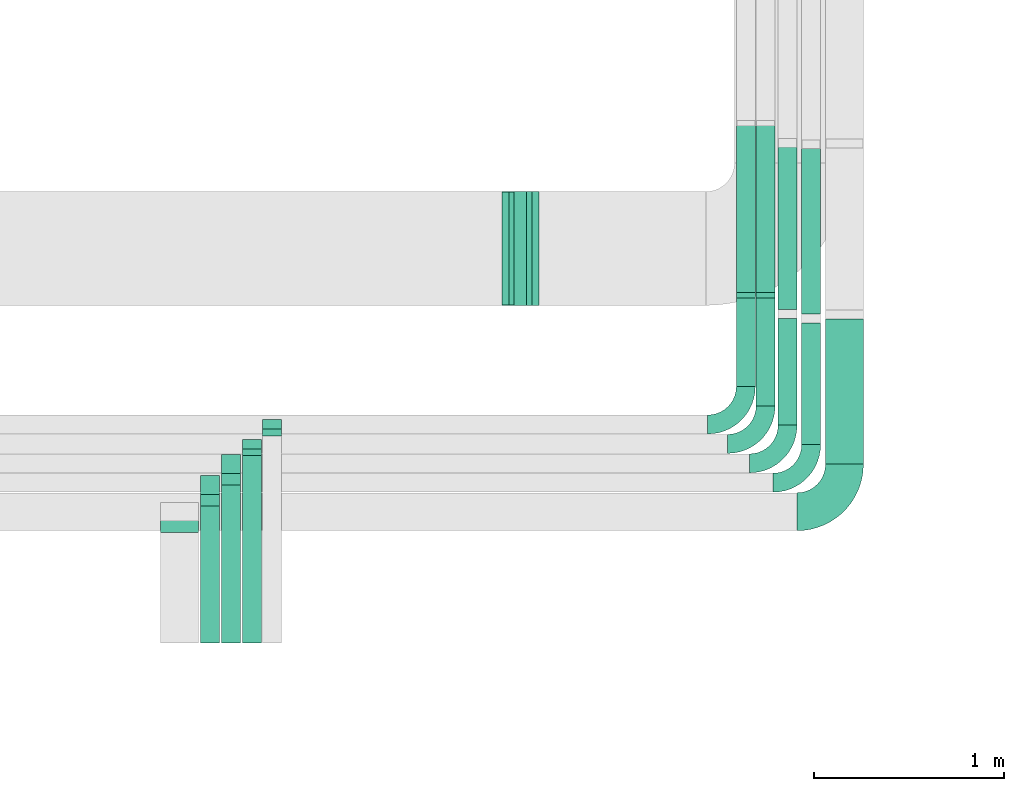
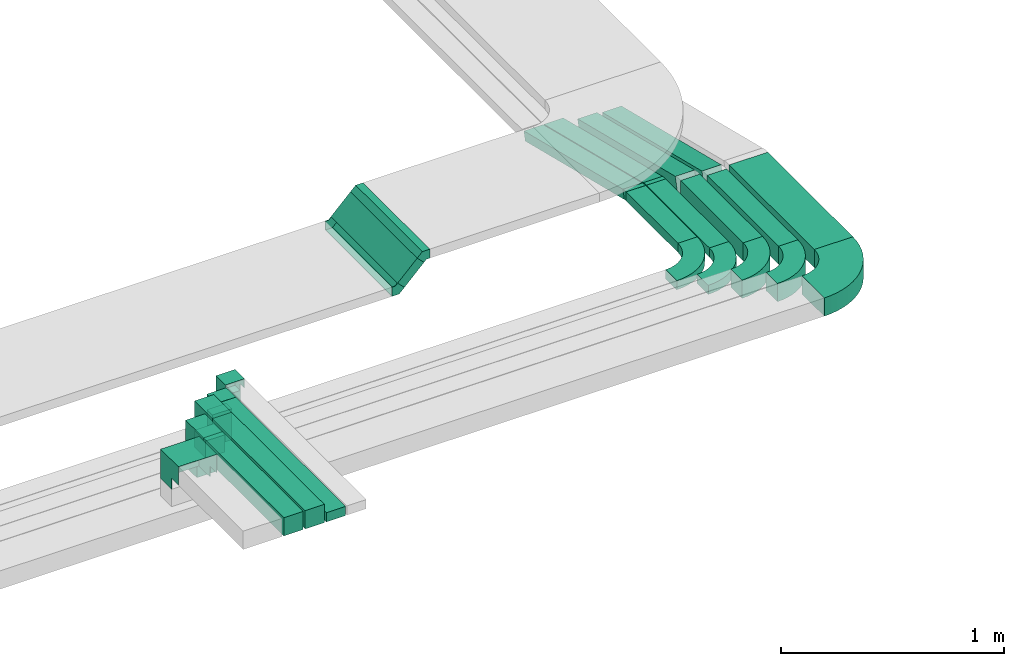
# One storey, part 17 of 38: 17 flow segments, 14 flow fittings.
"""IFC2X3 building model written with IfcOpenShell, lengths in millimetres."""

import ifcopenshell
import ifcopenshell.guid

model = None  # the IFC model being written
_history = None  # IfcOwnerHistory: only IFC2X3 demands one
_inside = {}  # id of a spatial element -> (the spatial element, [elements in it])
_under = {}  # id of a project, library or spatial element -> (it, [spatial elements below it])
_declared = {}  # id of a project -> (the project, [libraries it declares])
_typed = {}  # id of a type object -> (the type object, [elements of that type])
_made_of = {}  # id of a material, layer set ... -> (it, [elements and type objects made of it])


def new_model(schema):
    """Start an empty IFC model of exactly this schema.

    Asked for "IFC4X3", IfcOpenShell would pick the latest addendum, in which some entities
    have other attributes; the version numbers below select the first issue.
    IFC2X3 requires an IfcOwnerHistory on every rooted entity: one is made here for all.
    """
    global model, _history
    if schema == "IFC4X3":
        model = ifcopenshell.file(schema_version=(4, 3, 0, 0))
    else:
        model = ifcopenshell.file(schema=schema)
    _inside.clear()
    _under.clear()
    _declared.clear()
    _typed.clear()
    _made_of.clear()
    _history = None
    if model.schema == "IFC2X3":
        org = make("IfcOrganization", Name="unknown")
        user = make(
            "IfcPersonAndOrganization",
            ThePerson=make("IfcPerson", FamilyName="unknown"),
            TheOrganization=org,
        )
        app = make(
            "IfcApplication",
            ApplicationDeveloper=org,
            Version="unknown",
            ApplicationFullName="unknown",
            ApplicationIdentifier="unknown",
        )
        _history = make(
            "IfcOwnerHistory",
            OwningUser=user,
            OwningApplication=app,
            ChangeAction="ADDED",
            CreationDate=0,
        )
    return model


def make(cls, **values):
    """One entity of the class cls with the attributes given. An attribute that is None is left unset."""
    return model.create_entity(
        cls, **{name: value for name, value in values.items() if value is not None}
    )


def entity(cls, *values):
    """Any entity or typed value of the class cls, its attributes in the order of the schema. None: left unset."""
    e = model.create_entity(cls)
    for i, value in enumerate(values):
        if value is not None:
            e[i] = value
    return e


def rooted(cls, **values):
    """An entity with a GlobalId (a new one), such as an element, a storey or a relation."""
    return make(cls, GlobalId=ifcopenshell.guid.new(), OwnerHistory=_history, **values)


def si_unit(unit_type, name, prefix=None):
    """IfcSIUnit, for example si_unit("LENGTHUNIT", "METRE", prefix="MILLI")."""
    return make("IfcSIUnit", UnitType=unit_type, Prefix=prefix, Name=name)


def converted_unit(unit_type, name, factor, base, dimensions=None, offset=None):
    """IfcConversionBasedUnit, such as the inch: factor (a typed value) times the base unit."""
    return make(
        "IfcConversionBasedUnit"
        if offset is None
        else "IfcConversionBasedUnitWithOffset",
        ConversionOffset=offset,
        Dimensions=None
        if dimensions is None
        else entity("IfcDimensionalExponents", *dimensions),
        UnitType=unit_type,
        Name=name,
        ConversionFactor=make(
            "IfcMeasureWithUnit", ValueComponent=factor, UnitComponent=base
        ),
    )


def derived_unit(unit_type, elements):
    """IfcDerivedUnit: a product of units, each with its exponent."""
    return make(
        "IfcDerivedUnit",
        Elements=[
            make("IfcDerivedUnitElement", Unit=unit, Exponent=power)
            for unit, power in elements
        ],
        UnitType=unit_type,
    )


def assignment(units):
    """IfcUnitAssignment: the units of a project."""
    return None if units is None else make("IfcUnitAssignment", Units=units)


def point(xyz):
    """IfcCartesianPoint."""
    return None if xyz is None else make("IfcCartesianPoint", Coordinates=xyz)


def direction(xyz):
    """IfcDirection."""
    return None if xyz is None else make("IfcDirection", DirectionRatios=xyz)


def frame(location, z_axis=None, x_axis=None):
    """IfcAxis2Placement3D, a coordinate frame: its origin and axes. An axis left out is left unset."""
    return make(
        "IfcAxis2Placement3D",
        Location=point(location),
        Axis=direction(z_axis),
        RefDirection=direction(x_axis),
    )


def frame_2d(location, x_axis=None):
    """IfcAxis2Placement2D, a coordinate frame in the plane: its origin and x axis."""
    return make(
        "IfcAxis2Placement2D", Location=point(location), RefDirection=direction(x_axis)
    )


def origin():
    """The frame at (0, 0, 0) with its axes left unset."""
    return frame((0.0, 0.0, 0.0))


def origin_2d_with_axis():
    """The frame at (0, 0) in the plane with the x axis (1, 0) written out."""
    return frame_2d((0.0, 0.0), x_axis=(1.0, 0.0))


def place(relative_to, where):
    """IfcLocalPlacement: puts the frame where relative to a parent placement (None: the world)."""
    return make(
        "IfcLocalPlacement", PlacementRelTo=relative_to, RelativePlacement=where
    )


def context(
    kind, dimensions, precision=None, world=None, true_north=None, identifier=None
):
    """IfcGeometricRepresentationContext, for example the 3D "Model" context."""
    return make(
        "IfcGeometricRepresentationContext",
        ContextIdentifier=identifier,
        ContextType=kind,
        CoordinateSpaceDimension=dimensions,
        Precision=precision,
        WorldCoordinateSystem=world,
        TrueNorth=true_north,
    )


def subcontext(parent, identifier, kind, view, scale=None):
    """IfcGeometricRepresentationSubContext, for example "Body" below "Model"."""
    return make(
        "IfcGeometricRepresentationSubContext",
        ContextIdentifier=identifier,
        ContextType=kind,
        ParentContext=parent,
        TargetScale=scale,
        TargetView=view,
    )


def project(units=None, contexts=None):
    """IfcProject with its units and contexts."""
    return rooted(
        "IfcProject",
        Name="project",
        RepresentationContexts=contexts,
        UnitsInContext=assignment(units),
    )


def spatial(cls, under=None, at=None, **own):
    """A site, building, storey or space (cls), placed at a placement, below another one or the project."""
    s = rooted(cls, ObjectPlacement=at, **own)
    if under is not None:
        _under.setdefault(under.id(), (under, []))[1].append(s)
    return s


def polyline(points):
    """IfcPolyline through the points."""
    return make("IfcPolyline", Points=[point(p) for p in points])


def circle_curve(where, radius):
    """IfcCircle in the frame where."""
    return make("IfcCircle", Position=where, Radius=radius)


def parameter(value):
    """IfcParameterValue: where a trimmed curve begins or ends, as a parameter of its basis curve."""
    return model.create_entity("IfcParameterValue", value)


def trimmed(basis, trim1, trim2, sense, master):
    """IfcTrimmedCurve: the piece of a basis curve between two trims."""
    return make(
        "IfcTrimmedCurve",
        BasisCurve=basis,
        Trim1=trim1,
        Trim2=trim2,
        SenseAgreement=sense,
        MasterRepresentation=master,
    )


def segment(curve, same_sense, transition):
    """IfcCompositeCurveSegment."""
    return make(
        "IfcCompositeCurveSegment",
        Transition=transition,
        SameSense=same_sense,
        ParentCurve=curve,
    )


def composite_curve(segments, self_intersect=None):
    """IfcCompositeCurve: segments joined end to end."""
    return make("IfcCompositeCurve", Segments=segments, SelfIntersect=self_intersect)


def profile(cls, at=None, kind="AREA", **sizes):
    """A parametric profile (cls). Its sizes go by their IFC names, for example OverallWidth=200.0."""
    return make(cls, ProfileType=kind, Position=at, **sizes)


def rectangle(**sizes):
    """IfcRectangleProfileDef."""
    return profile("IfcRectangleProfileDef", **sizes)


def outline(outer, holes=None, kind="AREA"):
    """IfcArbitraryClosedProfileDef: a profile drawn as a closed curve; with holes, ...WithVoids."""
    if holes is None:
        return make("IfcArbitraryClosedProfileDef", ProfileType=kind, OuterCurve=outer)
    return make(
        "IfcArbitraryProfileDefWithVoids",
        ProfileType=kind,
        OuterCurve=outer,
        InnerCurves=holes,
    )


def extrude(swept, where, along, depth):
    """IfcExtrudedAreaSolid: the profile swept, set in the frame where, extruded along a direction by depth."""
    return make(
        "IfcExtrudedAreaSolid",
        SweptArea=swept,
        Position=where,
        ExtrudedDirection=direction(along),
        Depth=depth,
    )


def faces_of(points, faces, orient=None, outer=None):
    """IfcFace entities. A face is a list of loops; a loop is a list of indices into points, from 0.

    orient and outer hold one flag for each loop. By default every Orientation is true, the
    first loop of a face is its IfcFaceOuterBound and the others are IfcFaceBound.
    """
    made = []
    for i, loops in enumerate(faces):
        bounds = []
        for j, loop in enumerate(loops):
            is_outer = j == 0 if outer is None else outer[i][j]
            bounds.append(
                make(
                    "IfcFaceOuterBound" if is_outer else "IfcFaceBound",
                    Bound=make("IfcPolyLoop", Polygon=[points[k] for k in loop]),
                    Orientation=True if orient is None else orient[i][j],
                )
            )
        made.append(make("IfcFace", Bounds=bounds))
    return made


def faceted_brep(points, faces, orient=None, outer=None, voids=None):
    """IfcFacetedBrep: a solid bounded by flat faces; with voids (closed shells), ...WithVoids."""
    shared = [point(p) for p in points]
    hull = make("IfcClosedShell", CfsFaces=faces_of(shared, faces, orient, outer))
    if voids is None:
        return make("IfcFacetedBrep", Outer=hull)
    return make(
        "IfcFacetedBrepWithVoids",
        Outer=hull,
        Voids=[
            make(cls, CfsFaces=faces_of(shared, fs, o, b)) for cls, fs, o, b in voids
        ],
    )


def shape(context_of_items, identifier, shape_type, items):
    """IfcShapeRepresentation: the items that make up one representation, for example the "Body"."""
    return make(
        "IfcShapeRepresentation",
        ContextOfItems=context_of_items,
        RepresentationIdentifier=identifier,
        RepresentationType=shape_type,
        Items=items,
    )


def source(mapping_origin, context_of_items, identifier, shape_type, items):
    """IfcRepresentationMap: a shape defined once, which mapped items show again and again."""
    return make(
        "IfcRepresentationMap",
        MappingOrigin=mapping_origin,
        MappedRepresentation=shape(context_of_items, identifier, shape_type, items),
    )


def transform(
    local_origin,
    x_axis=None,
    y_axis=None,
    z_axis=None,
    scale=None,
    scale2=None,
    scale3=None,
    uniform=True,
):
    """IfcCartesianTransformationOperator3D, or its non-uniform kind. x_axis, y_axis, z_axis: its Axis1, 2, 3."""
    if uniform:
        return make(
            "IfcCartesianTransformationOperator3D",
            Axis1=direction(x_axis),
            Axis2=direction(y_axis),
            LocalOrigin=point(local_origin),
            Scale=scale,
            Axis3=direction(z_axis),
        )
    return make(
        "IfcCartesianTransformationOperator3DnonUniform",
        Axis1=direction(x_axis),
        Axis2=direction(y_axis),
        LocalOrigin=point(local_origin),
        Scale=scale,
        Axis3=direction(z_axis),
        Scale2=scale2,
        Scale3=scale3,
    )


def mapped(mapping_source, mapping_target):
    """IfcMappedItem: shows the shape of a source again, moved by a transform."""
    return make(
        "IfcMappedItem", MappingSource=mapping_source, MappingTarget=mapping_target
    )


def material(Name=None, Category=None):
    """IfcMaterial."""
    return make("IfcMaterial", Name=Name, Category=Category)


def made_of(thing, what):
    """Note that an element or type object is made of a material, layer set ...; save() writes the relation."""
    if what is not None:
        _made_of.setdefault(what.id(), (what, []))[1].append(thing)
    return thing


def type_object(cls, material=None, **own):
    """A type object (cls), such as IfcWallType, which elements share."""
    return made_of(rooted(cls, **own), material)


def type_shapes(of_type, sources):
    """Give a type object the sources (RepresentationMaps) that its elements show as mapped items."""
    of_type.RepresentationMaps = sources


def element(
    cls,
    number,
    at=None,
    inside=None,
    cuts=None,
    type_object=None,
    material=None,
    context=None,
    identifier="Body",
    shape_type=None,
    held_by="IfcProductDefinitionShape",
    body=None,
    shapes=None,
    **own,
):
    """One element of the class cls, such as IfcWall. Its Tag is "e" and its number.

    at: its placement. inside: the storey or other place that contains it. cuts: it is an
    opening in that element (IfcRelVoidsElement). A single representation is given by context,
    identifier, shape_type and body (its items); several are given by shapes. held_by: the class
    of the entity that holds the representations. save() writes the other relations.
    """
    e = rooted(cls, Tag="e%d" % number, ObjectPlacement=at, **own)
    if body is not None:
        shapes = [shape(context, identifier, shape_type, body)]
    if shapes is not None:
        e.Representation = make(held_by, Representations=shapes)
    if inside is not None:
        _inside.setdefault(inside.id(), (inside, []))[1].append(e)
    if cuts is not None:
        rooted(
            "IfcRelVoidsElement", RelatingBuildingElement=cuts, RelatedOpeningElement=e
        )
    if type_object is not None:
        _typed.setdefault(type_object.id(), (type_object, []))[1].append(e)
    return made_of(e, material)


def aggregate(whole, parts):
    """IfcRelAggregates: a whole, such as a stair, and the parts it consists of."""
    return rooted("IfcRelAggregates", RelatingObject=whole, RelatedObjects=parts)


def save(model, path):
    """Write the relations noted so far, then the file.

    IfcRelAggregates (storeys below a building ...), IfcRelContainedInSpatialStructure (elements
    in a storey), IfcRelDefinesByType, IfcRelAssociatesMaterial and IfcRelDeclares: one each for
    every whole, place, type object, material and project.
    """
    for whole, parts in _under.values():
        aggregate(whole, parts)
    for where, things in _inside.values():
        rooted(
            "IfcRelContainedInSpatialStructure",
            RelatedElements=things,
            RelatingStructure=where,
        )
    for kind, things in _typed.values():
        rooted("IfcRelDefinesByType", RelatedObjects=things, RelatingType=kind)
    for what, things in _made_of.values():
        rooted("IfcRelAssociatesMaterial", RelatedObjects=things, RelatingMaterial=what)
    for by, libraries in _declared.values():
        rooted("IfcRelDeclares", RelatingContext=by, RelatedDefinitions=libraries)
    model.write(path)


model = new_model("IFC2X3")

# Units and contexts
model_context = context("Model", 3, precision=0.01, world=origin(), true_north=direction((6.12303176911189e-17, 1.0)))
body_context = subcontext(model_context, "Body", "Model", "MODEL_VIEW")
ifc_project = project(units=[si_unit("LENGTHUNIT", "METRE", prefix="MILLI"), si_unit("AREAUNIT", "SQUARE_METRE"), si_unit("VOLUMEUNIT", "CUBIC_METRE"), converted_unit("PLANEANGLEUNIT", "DEGREE", entity("IfcRatioMeasure", 0.0174532925199433), si_unit("PLANEANGLEUNIT", "RADIAN"), dimensions=[0, 0, 0, 0, 0, 0, 0]), si_unit("MASSUNIT", "GRAM", prefix="KILO"), derived_unit("MASSDENSITYUNIT", [(si_unit("MASSUNIT", "GRAM", prefix="KILO"), 1), (si_unit("LENGTHUNIT", "METRE"), -3)]), derived_unit("MOMENTOFINERTIAUNIT", [(si_unit("LENGTHUNIT", "METRE"), 4)]), si_unit("TIMEUNIT", "SECOND"), si_unit("FREQUENCYUNIT", "HERTZ"), si_unit("THERMODYNAMICTEMPERATUREUNIT", "DEGREE_CELSIUS"), derived_unit("THERMALTRANSMITTANCEUNIT", [(si_unit("MASSUNIT", "GRAM", prefix="KILO"), 1), (si_unit("THERMODYNAMICTEMPERATUREUNIT", "KELVIN"), -1), (si_unit("TIMEUNIT", "SECOND"), -3)]), derived_unit("VOLUMETRICFLOWRATEUNIT", [(si_unit("LENGTHUNIT", "METRE"), 3), (si_unit("TIMEUNIT", "SECOND"), -1)]), derived_unit("MASSFLOWRATEUNIT", [(si_unit("MASSUNIT", "GRAM", prefix="KILO"), 1), (si_unit("TIMEUNIT", "SECOND"), -1)]), derived_unit("ROTATIONALFREQUENCYUNIT", [(si_unit("TIMEUNIT", "SECOND"), -1)]), si_unit("ELECTRICCURRENTUNIT", "AMPERE"), si_unit("ELECTRICVOLTAGEUNIT", "VOLT"), si_unit("POWERUNIT", "WATT"), si_unit("FORCEUNIT", "NEWTON", prefix="KILO"), si_unit("ILLUMINANCEUNIT", "LUX"), si_unit("LUMINOUSFLUXUNIT", "LUMEN"), si_unit("LUMINOUSINTENSITYUNIT", "CANDELA"), derived_unit("USERDEFINED", [(si_unit("MASSUNIT", "GRAM", prefix="KILO"), -1), (si_unit("LENGTHUNIT", "METRE"), -2), (si_unit("TIMEUNIT", "SECOND"), 3), (si_unit("LUMINOUSFLUXUNIT", "LUMEN"), 1)]), derived_unit("LINEARVELOCITYUNIT", [(si_unit("LENGTHUNIT", "METRE"), 1), (si_unit("TIMEUNIT", "SECOND"), -1)]), si_unit("PRESSUREUNIT", "PASCAL"), derived_unit("USERDEFINED", [(si_unit("LENGTHUNIT", "METRE"), -2), (si_unit("MASSUNIT", "GRAM", prefix="KILO"), 1), (si_unit("TIMEUNIT", "SECOND"), -2)]), derived_unit("LINEARFORCEUNIT", [(si_unit("MASSUNIT", "GRAM", prefix="KILO"), 1), (si_unit("LENGTHUNIT", "METRE"), 1), (si_unit("TIMEUNIT", "SECOND"), -2), (si_unit("LENGTHUNIT", "METRE"), -1)]), derived_unit("PLANARFORCEUNIT", [(si_unit("MASSUNIT", "GRAM", prefix="KILO"), 1), (si_unit("LENGTHUNIT", "METRE"), 1), (si_unit("TIMEUNIT", "SECOND"), -2), (si_unit("LENGTHUNIT", "METRE"), -2)])], contexts=[model_context])

# Site, building, storey
site_placement = place(None, frame((0.0, -0.00077364408347762, 0.0)))
site = spatial("IfcSite", under=ifc_project, at=site_placement, CompositionType="ELEMENT")
building_placement = place(site_placement, origin())
building = spatial("IfcBuilding", under=site, at=building_placement, CompositionType="ELEMENT")
storey_placement = place(building_placement, frame((0.0, 0.0, 4200.0)))
storey = spatial("IfcBuildingStorey", under=building, at=storey_placement, CompositionType="ELEMENT", Elevation=4200.0)

# Flow segments
cable_carrier_segment_type = type_object("IfcCableCarrierSegmentType", PredefinedType="CABLETRAYSEGMENT")
flow_segment_1_placement = place(storey_placement, frame((23008.86951347, 12205.0299176423, 2750.0)))
element("IfcFlowSegment", 1, at=flow_segment_1_placement, inside=storey, type_object=cable_carrier_segment_type, context=body_context, shape_type="SweptSolid", body=[
    extrude(rectangle(XDim=464.808512947677, YDim=100.000000000003, at=frame_2d((-1.08002495835535e-12, 2.16715534406831e-12), x_axis=(1.0, 0.0))), frame((50.0, 232.404256473843, 0.0), z_axis=(0.0, 0.0, 1.0), x_axis=(0.0, 1.0, 0.0)), (0.0, 0.0, 1.0), 50.0000000000005),
])
flow_segment_2_placement = place(storey_placement, frame((23113.0702916723, 12102.5299176423, 2750.0)))
element("IfcFlowSegment", 2, at=flow_segment_2_placement, inside=storey, type_object=cable_carrier_segment_type, context=body_context, shape_type="SweptSolid", body=[
    extrude(rectangle(XDim=567.308512947676, YDim=100.000000000003, at=frame_2d((-1.08002495835535e-12, -2.16715534406831e-12), x_axis=(1.0, 0.0))), frame((50.0, 283.654256473842, 0.0), z_axis=(0.0, 0.0, 1.0), x_axis=(0.0, 1.0, 0.0)), (0.0, 0.0, 1.0), 49.9999999999995),
])
flow_segment_3_placement = place(storey_placement, frame((23228.86951347, 11999.9581146252, 2750.0)))
element("IfcFlowSegment", 3, at=flow_segment_3_placement, inside=storey, type_object=cable_carrier_segment_type, context=body_context, shape_type="SweptSolid", body=[
    extrude(rectangle(XDim=562.575454640019, YDim=100.000000000003, at=frame_2d((-1.08002495835535e-12, 0.0), x_axis=(1.0, 0.0))), frame((50.0, 281.287727320011, 0.0), z_axis=(0.0, 0.0, 1.0), x_axis=(0.0, 1.0, 0.0)), (0.0, 0.0, 1.0), 99.9999999999989),
])
flow_segment_4_placement = place(storey_placement, frame((23353.0702916724, 11897.8541189971, 2750.0)))
element("IfcFlowSegment", 4, at=flow_segment_4_placement, inside=storey, type_object=cable_carrier_segment_type, context=body_context, shape_type="SweptSolid", body=[
    extrude(rectangle(XDim=640.748055056679, YDim=100.000000000003, at=frame_2d((1.08002495835535e-12, 0.0), x_axis=(1.0, 0.0))), frame((50.0, 320.37402752834, 0.0), z_axis=(0.0, 0.0, 1.0), x_axis=(0.0, 1.0, 0.0)), (0.0, 0.0, 1.0), 99.9999999999989),
])
flow_segment_5_placement = place(storey_placement, frame((23478.9930091024, 11794.7857236441, 2750.0)))
element("IfcFlowSegment", 5, at=flow_segment_5_placement, inside=storey, type_object=cable_carrier_segment_type, context=body_context, shape_type="SweptSolid", body=[
    extrude(rectangle(XDim=764.964137194482, YDim=199.999999999998, at=origin_2d_with_axis()), frame((100.0, 382.482068597242, 0.0), z_axis=(0.0, 0.0, 1.0), x_axis=(0.0, 1.0, 0.0)), (0.0, 0.0, 1.0), 99.9999999999989),
])
flow_segment_6_placement = place(storey_placement, frame((23008.86951347, 12686.8858983174, 2528.02365959367)))
element("IfcFlowSegment", 6, at=flow_segment_6_placement, inside=storey, type_object=cable_carrier_segment_type, context=body_context, shape_type="SweptSolid", body=[
    extrude(rectangle(XDim=50.0000000000011, YDim=917.109318453488, at=frame_2d((1.05160324892495e-12, 2.54019028034236e-13), x_axis=(0.0, 1.0))), frame((0.0, 451.172069580576, 134.221839741608), z_axis=(1.0, 0.0, 0.0), x_axis=(0.0, 0.970827839564386, -0.239777617651748)), (0.0, 0.0, 1.0), 100.000000000003),
])
flow_segment_7_placement = place(storey_placement, frame((23113.0702916723, 12686.8858983174, 2528.02365959368)))
element("IfcFlowSegment", 7, at=flow_segment_7_placement, inside=storey, type_object=cable_carrier_segment_type, context=body_context, shape_type="SweptSolid", body=[
    extrude(rectangle(XDim=50.0000000000006, YDim=917.109318453461, at=frame_2d((1.02318153949454e-12, 2.52242671194836e-13), x_axis=(0.0, 1.0))), frame((0.0, 451.172069580563, 134.221839741601), z_axis=(1.0, 0.0, 0.0), x_axis=(0.0, 0.970827839564387, -0.23977761765174)), (0.0, 0.0, 1.0), 100.000000000003),
])
flow_segment_8_placement = place(storey_placement, frame((23228.86951347, 12585.5754774339, 2530.21157162635)))
element("IfcFlowSegment", 8, at=flow_segment_8_placement, inside=storey, type_object=cable_carrier_segment_type, context=body_context, shape_type="SweptSolid", body=[
    extrude(rectangle(XDim=100.000000000001, YDim=904.942978358351, at=frame_2d((-1.05160324892495e-12, -2.52242671194836e-13), x_axis=(0.0, 1.0))), frame((0.0, 451.260799186891, 157.033927708937), z_axis=(1.0, 0.0, 0.0), x_axis=(0.0, 0.970827839564388, -0.239777617651738)), (0.0, 0.0, 1.0), 100.000000000003),
])
flow_segment_9_placement = place(storey_placement, frame((23353.0702916724, 12561.6440822225, 2525.88521243132)))
element("IfcFlowSegment", 9, at=flow_segment_9_placement, inside=storey, type_object=cable_carrier_segment_type, context=body_context, shape_type="SweptSolid", body=[
    extrude(rectangle(XDim=100.000000000001, YDim=922.986193723503, at=frame_2d((1.02318153949454e-12, 2.52242671194836e-13), x_axis=(0.0, 1.0))), frame((0.0, 460.019227082757, 159.197107306454), z_axis=(1.0, 0.0, 0.0), x_axis=(0.0, 0.970827839564388, -0.239777617651739)), (0.0, 0.0, 1.0), 100.000000000003),
])
flow_segment_10_placement = place(storey_placement, frame((21801.7409255696, 12632.0485020162, 2709.73789138054)))
element("IfcFlowSegment", 10, at=flow_segment_10_placement, inside=storey, type_object=cable_carrier_segment_type, context=body_context, shape_type="SweptSolid", body=[
    extrude(rectangle(XDim=143.47907825232, YDim=49.999999999998, at=frame_2d((-3.83693077310454e-13, 3.81916720471054e-13), x_axis=(1.0, 0.0))), frame((68.4051841250009, 0.0, 68.4051841250129), z_axis=(0.0, 1.0, 0.0), x_axis=(0.707106781186502, 0.0, 0.707106781186593)), (0.0, 0.0, 1.0), 599.999999999998),
])
flow_segment_11_placement = place(storey_placement, frame((20510.9642990801, 11979.0299176424, 2800.0)))
element("IfcFlowSegment", 11, at=flow_segment_11_placement, inside=storey, type_object=cable_carrier_segment_type, context=body_context, shape_type="SweptSolid", body=[
    extrude(rectangle(XDim=100.000000000003, YDim=50.0000000000016, at=origin_2d_with_axis()), frame((50.0, 25.0, 0.0)), (0.0, 0.0, 1.0), 170.000000000004),
])
flow_segment_12_placement = place(storey_placement, frame((20404.3597987713, 10851.673044066, 3005.0)))
element("IfcFlowSegment", 12, at=flow_segment_12_placement, inside=storey, type_object=cable_carrier_segment_type, context=body_context, shape_type="SweptSolid", body=[
    extrude(rectangle(XDim=987.987059231862, YDim=100.000000000003, at=frame_2d((1.08002495835535e-12, 2.16715534406831e-12), x_axis=(1.0, 0.0))), frame((50.0, 493.993529615932, 0.0), z_axis=(0.0, 0.0, 1.0), x_axis=(0.0, -1.0, 0.0)), (0.0, 0.0, 1.0), 50.0000000000005),
])
flow_segment_13_placement = place(storey_placement, frame((20404.2705021026, 11874.4810280765, 2800.0)))
element("IfcFlowSegment", 13, at=flow_segment_13_placement, inside=storey, type_object=cable_carrier_segment_type, context=body_context, shape_type="SweptSolid", body=[
    extrude(rectangle(XDim=100.000000000004, YDim=50.000000000002, at=origin_2d_with_axis()), frame((50.0892966686903, 25.1790752212726, 0.0), z_axis=(0.0, 0.0, 1.0), x_axis=(0.999993574881429, -0.00358471698463083, 0.0)), (0.0, 0.0, 1.0), 170.000000000003),
])
flow_segment_14_placement = place(storey_placement, frame((20293.8464699162, 10851.673044066, 3005.0)))
element("IfcFlowSegment", 14, at=flow_segment_14_placement, inside=storey, type_object=cable_carrier_segment_type, context=body_context, shape_type="SweptSolid", body=[
    extrude(rectangle(XDim=833.264768275426, YDim=100.000000000003, at=frame_2d((1.08002495835535e-12, -2.16715534406831e-12), x_axis=(1.0, 0.0))), frame((50.0, 416.632384137714, 0.0), z_axis=(0.0, 0.0, 1.0), x_axis=(0.0, -1.0, 0.0)), (0.0, 0.0, 1.0), 99.9999999999989),
])
flow_segment_15_placement = place(storey_placement, frame((20293.8464699162, 11744.9378123414, 2850.05423001616)))
element("IfcFlowSegment", 15, at=flow_segment_15_placement, inside=storey, type_object=cable_carrier_segment_type, context=body_context, shape_type="SweptSolid", body=[
    extrude(rectangle(XDim=100.00000001767, YDim=99.9999999999989, at=origin_2d_with_axis()), frame((50.0, 50.0, 0.000939853973139293), z_axis=(1.87970794378071e-05, 0.0, 1.0), x_axis=(-1.0, 0.0, 1.87970794378071e-05)), (1.87970794378071e-05, 0.0, 1.0), 94.9448301466394),
])
flow_segment_16_placement = place(storey_placement, frame((20183.7710465603, 11633.744448405, 2850.0)))
element("IfcFlowSegment", 16, at=flow_segment_16_placement, inside=storey, type_object=cable_carrier_segment_type, context=body_context, shape_type="SweptSolid", body=[
    extrude(rectangle(XDim=100.000000000003, YDim=99.9999999999989, at=origin_2d_with_axis()), frame((50.0, 50.0, 0.0)), (0.0, 0.0, 1.0), 95.0000000000066),
])
flow_segment_17_placement = place(storey_placement, frame((20183.7710465603, 10851.673044066, 3005.0)))
element("IfcFlowSegment", 17, at=flow_segment_17_placement, inside=storey, type_object=cable_carrier_segment_type, context=body_context, shape_type="SweptSolid", body=[
    extrude(rectangle(XDim=722.071404339018, YDim=100.000000000003, at=frame_2d((1.10844666778576e-12, -2.16715534406831e-12), x_axis=(1.0, 0.0))), frame((50.0, 361.03570216951, 0.0), z_axis=(0.0, 0.0, 1.0), x_axis=(0.0, -1.0, 0.0)), (0.0, 0.0, 1.0), 99.9999999999989),
])

# Flow fittings
ifc_material = material()
cable_carrier_fitting_type_1 = type_object("IfcCableCarrierFittingType", Name="470_DKC_S5_Variable Angle Elbow 0-45:-", PredefinedType="NOTDEFINED", material=ifc_material)
shared_shape_1 = source(origin(), body_context, "Body", "SweptSolid", [
    extrude(outline(composite_curve([segment(polyline([(-125.750000000001, -225.25), (-124.749999999999, -225.25)]), True, "CONTINUOUS"), segment(trimmed(circle_curve(frame_2d((-124.75, 124.75), x_axis=(0.0, -1.0)), 350.0), [parameter(0.0)], [parameter(90.0000000000001)], True, "PARAMETER"), True, "CONTINUOUS"), segment(polyline([(225.25, 124.75), (225.25, 125.749999999999)]), True, "CONTINUOUS"), segment(polyline([(225.25, 125.749999999999), (25.25, 125.750000000001)]), True, "CONTINUOUS"), segment(polyline([(25.25, 125.750000000001), (25.25, 124.75)]), True, "CONTINUOUS"), segment(trimmed(circle_curve(frame_2d((-124.75, 124.75), x_axis=(0.0, -1.0)), 150.0), [parameter(0.0)], [parameter(90.0000000000001)], True, "PARAMETER"), False, "CONTINUOUS"), segment(polyline([(-124.749999999999, -25.2500000000003), (-125.750000000001, -25.2500000000003)]), True, "CONTINUOUS"), segment(polyline([(-125.750000000001, -25.2500000000003), (-125.750000000001, -225.25)]), True, "CONTINUOUS")], self_intersect=False)), frame((-125.249999999991, 125.249999999992, -50.0)), (0.0, 0.0, 1.0), 100.0),
])
type_shapes(cable_carrier_fitting_type_1, [shared_shape_1])
flow_fitting_1_placement = place(storey_placement, frame((23578.9930091024, 11543.7857236441, 2800.0)))
element("IfcFlowFitting", 18, at=flow_fitting_1_placement, inside=storey, type_object=cable_carrier_fitting_type_1, material=ifc_material, Name="470_DKC_S5_Variable Angle Elbow 0-45:-", ObjectType="470_DKC_S5_Variable Angle Elbow 0-45:-", context=body_context, shape_type="MappedRepresentation", body=[
    mapped(shared_shape_1, transform((0.0, 0.0, 0.0), scale=1.0)),
])
cable_carrier_fitting_type_2 = type_object("IfcCableCarrierFittingType", Name="470_DKC_S5_Variable Angle Elbow 0-45:-", PredefinedType="NOTDEFINED", material=ifc_material)
shared_shape_2 = source(origin(), body_context, "Body", "SweptSolid", [
    extrude(outline(composite_curve([segment(polyline([(-100.749999999999, -150.250000000001), (-99.7499999999981, -150.250000000001)]), True, "CONTINUOUS"), segment(trimmed(circle_curve(frame_2d((-99.7500000000006, 99.7499999999987), x_axis=(0.0, -1.0)), 250.0), [parameter(0.0)], [parameter(90.0000000000001)], True, "PARAMETER"), True, "CONTINUOUS"), segment(polyline([(150.249999999999, 99.7500000000013), (150.249999999999, 100.750000000001)]), True, "CONTINUOUS"), segment(polyline([(150.249999999999, 100.750000000001), (50.2499999999992, 100.750000000001)]), True, "CONTINUOUS"), segment(polyline([(50.2499999999992, 100.750000000001), (50.2499999999992, 99.7500000000002)]), True, "CONTINUOUS"), segment(trimmed(circle_curve(frame_2d((-99.7500000000006, 99.7499999999987), x_axis=(0.0, -1.0)), 150.0), [parameter(0.0)], [parameter(90.0000000000001)], True, "PARAMETER"), False, "CONTINUOUS"), segment(polyline([(-99.7499999999989, -50.2500000000011), (-100.75, -50.2500000000011)]), True, "CONTINUOUS"), segment(polyline([(-100.75, -50.2500000000011), (-100.749999999999, -150.250000000001)]), True, "CONTINUOUS")], self_intersect=False)), frame((-100.249999999991, 100.249999999992, -50.0)), (0.0, 0.0, 1.0), 100.0),
])
type_shapes(cable_carrier_fitting_type_2, [shared_shape_2])
for number, where, name in (
    (19, (23403.0702916723, 11696.8541189971, 2800.0), "470_DKC_S5_Variable Angle Elbow 0-45:-"),
    (20, (23278.86951347, 11798.9581146253, 2800.0), "470_DKC_S5_Variable Angle Elbow 0-45:-"),
):
    element("IfcFlowFitting", number, at=place(storey_placement, frame(where)), inside=storey, type_object=cable_carrier_fitting_type_2, material=ifc_material, Name=name, ObjectType="470_DKC_S5_Variable Angle Elbow 0-45:-", context=body_context, shape_type="MappedRepresentation", body=[
        mapped(shared_shape_2, transform((0.0, 0.0, 0.0), scale=1.0)),
    ])
cable_carrier_fitting_type_3 = type_object("IfcCableCarrierFittingType", Name="470_DKC_S5_Variable Angle Elbow 0-45:-", PredefinedType="NOTDEFINED", material=ifc_material)
shared_shape_3 = source(origin(), body_context, "Body", "SweptSolid", [
    extrude(outline(composite_curve([segment(polyline([(-100.750000000001, -150.25), (-99.7499999999994, -150.25)]), True, "CONTINUOUS"), segment(trimmed(circle_curve(frame_2d((-99.7499999999997, 99.7499999999995), x_axis=(0.0, -1.0)), 250.0), [parameter(0.0)], [parameter(90.0000000000001)], True, "PARAMETER"), True, "CONTINUOUS"), segment(polyline([(150.25, 99.75), (150.25, 100.749999999999)]), True, "CONTINUOUS"), segment(polyline([(150.25, 100.749999999999), (50.25, 100.75)]), True, "CONTINUOUS"), segment(polyline([(50.25, 100.75), (50.25, 99.7499999999998)]), True, "CONTINUOUS"), segment(trimmed(circle_curve(frame_2d((-99.7499999999997, 99.7499999999995), x_axis=(0.0, -1.0)), 150.0), [parameter(0.0)], [parameter(90.0000000000001)], True, "PARAMETER"), False, "CONTINUOUS"), segment(polyline([(-99.7499999999994, -50.2500000000003), (-100.750000000001, -50.2500000000003)]), True, "CONTINUOUS"), segment(polyline([(-100.750000000001, -50.2500000000003), (-100.750000000001, -150.25)]), True, "CONTINUOUS")], self_intersect=False)), frame((-100.249999999991, 100.249999999992, -25.0)), (0.0, 0.0, 1.0), 49.9999999999997),
])
type_shapes(cable_carrier_fitting_type_3, [shared_shape_3])
for number, where, name in (
    (21, (23163.0702916723, 11901.5299176424, 2775.0), "470_DKC_S5_Variable Angle Elbow 0-45:-"),
    (22, (23058.86951347, 12004.0299176424, 2775.0), "470_DKC_S5_Variable Angle Elbow 0-45:-"),
):
    element("IfcFlowFitting", number, at=place(storey_placement, frame(where)), inside=storey, type_object=cable_carrier_fitting_type_3, material=ifc_material, Name=name, ObjectType="470_DKC_S5_Variable Angle Elbow 0-45:-", context=body_context, shape_type="MappedRepresentation", body=[
        mapped(shared_shape_3, transform((0.0, 0.0, 0.0), scale=1.0)),
    ])
cable_carrier_fitting_type_4 = type_object("IfcCableCarrierFittingType", PredefinedType="NOTDEFINED", material=ifc_material)
shared_shape_4 = source(origin(), body_context, "Body", "Brep", [
    faceted_brep([(-11.6914870523452, -25.0, 50.0), (-11.6914870523451, 25.0, 50.0), (-11.6914870523451, 25.0, 47.4600000101635), (-11.6914870523452, -22.46000001016, 47.4600000101635), (-11.6914870523452, -22.46000001016, -47.4600000101565), (-11.6914870523451, 25.0, -47.4600000101565), (-11.6914870523451, 25.0, -50.0), (-11.6914870523452, -25.0, -50.0), (17.3448615576182, -21.4673390768921, 50.0), (17.3448615576182, -21.4673390768921, -50.0), (5.35598067502984, 27.074052901327, -50.0), (5.35598067502983, 27.074052901327, -47.4600000101565), (16.7358264112189, -19.0014363742621, -47.4600000101565), (16.7358264112189, -19.0014363742622, 47.4600000101635), (5.35598067502984, 27.074052901327, 47.4600000101635), (5.35598067502984, 27.074052901327, 50.0), (3.04158502379381, -25.0, 50.0), (-3.04158502379305, 25.0, 50.0), (-3.04158502379305, 25.0, 47.4600000101635), (2.73255998661244, -22.46000001016, 47.4600000101635), (2.73255998661244, -22.46000001016, -47.4600000101565), (-3.04158502379305, 25.0, -47.4600000101565), (-3.04158502379305, 25.0, -50.0), (3.04158502379375, -25.0, -50.0)], [[[0, 1, 2, 3, 4, 5, 6, 7]], [[8, 9, 10, 11, 12, 13, 14, 15]], [[1, 0, 16, 8, 15, 17]], [[2, 1, 17, 18]], [[3, 2, 18, 14, 13, 19]], [[4, 3, 19, 20]], [[5, 4, 20, 12, 11, 21]], [[6, 5, 21, 22]], [[7, 6, 22, 10, 9, 23]], [[0, 7, 23, 16]], [[18, 17, 15, 14]], [[20, 19, 13, 12]], [[22, 21, 11, 10]], [[16, 23, 9, 8]]]),
])
type_shapes(cable_carrier_fitting_type_4, [shared_shape_4])
for number, where, z_axis, x_axis in (
    (23, (23058.86951347, 12681.5299176424, 2775.0), (-1.0, 0.0, 0.0), (0.0, 1.0, 0.0)),
    (24, (23163.0702916723, 12681.5299176424, 2775.0), (1.0, 0.0, 0.0), (0.0, -0.970827839564387, 0.239777617651742)),
):
    element("IfcFlowFitting", number, at=place(storey_placement, frame(where, z_axis=z_axis, x_axis=x_axis)), inside=storey, type_object=cable_carrier_fitting_type_4, material=ifc_material, context=body_context, shape_type="MappedRepresentation", body=[
        mapped(shared_shape_4, transform((0.0, 0.0, 0.0), scale=1.0)),
    ])
cable_carrier_fitting_type_5 = type_object("IfcCableCarrierFittingType", PredefinedType="NOTDEFINED", material=ifc_material)
shared_shape_5 = source(origin(), body_context, "Body", "Brep", [
    faceted_brep([(-27.7817459305286, -25.0, 300.0), (-27.7817459305285, 25.0, 300.0), (-27.7817459305285, 25.0, 297.460000010164), (-27.7817459305286, -22.4600000101599, 297.460000010164), (-27.7817459305286, -22.4600000101599, -297.460000010156), (-27.7817459305285, 25.0, -297.460000010156), (-27.7817459305285, 25.0, -300.0), (-27.7817459305286, -25.0, -300.0), (37.3223304703426, 1.96699141102481, 300.0), (37.3223304703426, 1.96699141102481, -300.0), (1.96699141100568, 37.3223304703426, -300.0), (1.96699141100567, 37.3223304703426, -297.460000010156), (35.5262792533125, 3.76304262805395, -297.460000010156), (35.5262792533125, 3.76304262805395, 297.460000010164), (1.96699141100568, 37.3223304703426, 297.460000010164), (1.96699141100568, 37.3223304703426, 300.0), (10.3553390593318, -25.0, 300.0), (-10.355339059331, 25.0, 300.0), (-10.355339059331, 25.0, 297.460000010164), (9.30323661511198, -22.46000001016, 297.460000010164), (9.30323661511198, -22.46000001016, -297.460000010156), (-10.355339059331, 25.0, -297.460000010156), (-10.355339059331, 25.0, -300.0), (10.3553390593316, -25.0, -300.0)], [[[0, 1, 2, 3, 4, 5, 6, 7]], [[8, 9, 10, 11, 12, 13, 14, 15]], [[1, 0, 16, 8, 15, 17]], [[2, 1, 17, 18]], [[3, 2, 18, 14, 13, 19]], [[4, 3, 19, 20]], [[5, 4, 20, 12, 11, 21]], [[6, 5, 21, 22]], [[7, 6, 22, 10, 9, 23]], [[0, 7, 23, 16]], [[18, 17, 15, 14]], [[20, 19, 13, 12]], [[22, 21, 11, 10]], [[16, 23, 9, 8]]]),
])
type_shapes(cable_carrier_fitting_type_5, [shared_shape_5])
for number, where, z_axis, x_axis in (
    (25, (21940.5182852305, 12932.0485020162, 2848.51525104152), (0.0, 1.0, 0.0), (0.707106781186492, 0.0, 0.707106781186603)),
    (26, (21799.7739341586, 12932.0485020162, 2707.77089996954), (0.0, 1.0, 0.0), (-0.70710678118654, 0.0, -0.707106781186555)),
):
    element("IfcFlowFitting", number, at=place(storey_placement, frame(where, z_axis=z_axis, x_axis=x_axis)), inside=storey, type_object=cable_carrier_fitting_type_5, material=ifc_material, context=body_context, shape_type="MappedRepresentation", body=[
        mapped(shared_shape_5, transform((0.0, 0.0, 0.0), scale=1.0)),
    ])
cable_carrier_fitting_type_6 = type_object("IfcCableCarrierFittingType", PredefinedType="NOTDEFINED", material=ifc_material)
shared_shape_6 = source(origin(), body_context, "Body", "Brep", [
    faceted_brep([(-110.0, -50.0, 100.0), (-110.0, 50.0, 100.0), (-110.0, 50.0, 97.4600000101635), (-110.0, -47.4600000101596, 97.4600000101635), (-110.0, -47.4600000101596, -97.4600000101564), (-110.0, 50.0, -97.4600000101564), (-110.0, 50.0, -100.0), (-110.0, -50.0, -100.0), (50.0, 110.0, 100.0), (50.0, 110.0, -100.0), (-50.0, 110.0, -100.0), (-50.0, 110.0, -97.4600000101564), (47.460000010161, 110.0, -97.4600000101565), (47.460000010161, 110.0, 97.4600000101635), (-50.0, 110.0, 97.4600000101635), (-50.0, 110.0, 100.0), (50.0, -50.0, 100.0), (-50.0, 50.0, 100.0), (-50.0, 50.0, 97.4600000101635), (47.4600000101603, -47.4600000101602, 97.4600000101635), (47.4600000101603, -47.4600000101601, -97.4600000101564), (-50.0, 50.0, -97.4600000101564), (-50.0, 50.0, -100.0), (50.0, -50.0, -100.0)], [[[0, 1, 2, 3, 4, 5, 6, 7]], [[8, 9, 10, 11, 12, 13, 14, 15]], [[1, 0, 16, 8, 15, 17]], [[2, 1, 17, 18]], [[3, 2, 18, 14, 13, 19]], [[4, 3, 19, 20]], [[5, 4, 20, 12, 11, 21]], [[6, 5, 21, 22]], [[7, 6, 22, 10, 9, 23]], [[0, 7, 23, 16]], [[18, 17, 15, 14]], [[20, 19, 13, 12]], [[22, 21, 11, 10]], [[16, 23, 9, 8]]]),
])
type_shapes(cable_carrier_fitting_type_6, [shared_shape_6])
flow_fitting_2_placement = place(storey_placement, frame((20072.9316203514, 11543.7857236441, 3055.0), z_axis=(-1.0, 0.0, 0.0), x_axis=(0.0, 1.0, 0.0)))
element("IfcFlowFitting", 27, at=flow_fitting_2_placement, inside=storey, type_object=cable_carrier_fitting_type_6, material=ifc_material, context=body_context, shape_type="MappedRepresentation", body=[
    mapped(shared_shape_6, transform((0.0, 0.0, 0.0), scale=1.0)),
])
cable_carrier_fitting_type_7 = type_object("IfcCableCarrierFittingType", PredefinedType="NOTDEFINED", material=ifc_material)
shared_shape_7 = source(origin(), body_context, "Body", "Brep", [
    faceted_brep([(-110.0, -50.0, 50.0), (-110.0, 50.0, 50.0), (-110.0, 50.0, 47.4600000101635), (-110.0, -47.4600000101596, 47.4600000101635), (-110.0, -47.4600000101596, -47.4600000101565), (-110.0, 50.0, -47.4600000101565), (-110.0, 50.0, -50.0), (-110.0, -50.0, -50.0), (50.0, 110.0, 50.0), (50.0, 110.0, -50.0), (-50.0, 110.0, -50.0), (-50.0, 110.0, -47.4600000101565), (47.460000010161, 110.0, -47.4600000101565), (47.460000010161, 110.0, 47.4600000101635), (-50.0, 110.0, 47.4600000101635), (-50.0, 110.0, 50.0), (50.0, -50.0, 50.0), (-50.0, 50.0, 50.0), (-50.0, 50.0, 47.4600000101635), (47.4600000101603, -47.4600000101602, 47.4600000101635), (47.4600000101603, -47.4600000101601, -47.4600000101565), (-50.0, 50.0, -47.4600000101565), (-50.0, 50.0, -50.0), (50.0, -50.0, -50.0)], [[[0, 1, 2, 3, 4, 5, 6, 7]], [[8, 9, 10, 11, 12, 13, 14, 15]], [[1, 0, 16, 8, 15, 17]], [[2, 1, 17, 18]], [[3, 2, 18, 14, 13, 19]], [[4, 3, 19, 20]], [[5, 4, 20, 12, 11, 21]], [[6, 5, 21, 22]], [[7, 6, 22, 10, 9, 23]], [[0, 7, 23, 16]], [[18, 17, 15, 14]], [[20, 19, 13, 12]], [[22, 21, 11, 10]], [[16, 23, 9, 8]]]),
])
type_shapes(cable_carrier_fitting_type_7, [shared_shape_7])
for number, where, z_axis, x_axis in (
    (28, (20343.8464699162, 11794.9378123414, 3055.0), (-1.0, 0.0, 0.0), (0.0, 1.0, 0.0)),
    (29, (20233.7710465603, 11683.744448405, 3055.0), (-1.0, 0.0, 0.0), (0.0, 1.0, 0.0)),
):
    element("IfcFlowFitting", number, at=place(storey_placement, frame(where, z_axis=z_axis, x_axis=x_axis)), inside=storey, type_object=cable_carrier_fitting_type_7, material=ifc_material, context=body_context, shape_type="MappedRepresentation", body=[
        mapped(shared_shape_7, transform((0.0, 0.0, 0.0), scale=1.0)),
    ])
cable_carrier_fitting_type_8 = type_object("IfcCableCarrierFittingType", PredefinedType="NOTDEFINED", material=ifc_material)
shared_shape_8 = source(origin(), body_context, "Body", "Brep", [
    faceted_brep([(-60.0, -25.0, 50.0), (-60.0, 25.0, 50.0), (-60.0, 25.0, 47.4600000101635), (-60.0, -22.4600000101598, 47.4600000101635), (-60.0, -22.4600000101598, -47.4600000101565), (-60.0, 25.0, -47.4600000101565), (-60.0, 25.0, -50.0), (-60.0, -25.0, -50.0), (25.0, 60.0, 50.0), (25.0, 60.0, -50.0), (-25.0, 60.0, -50.0), (-25.0, 60.0, -47.4600000101565), (22.4600000101609, 60.0, -47.4600000101565), (22.4600000101609, 60.0, 47.4600000101635), (-25.0, 60.0, 47.4600000101635), (-25.0, 60.0, 50.0), (25.0, -25.0, 50.0), (-25.0, 25.0, 50.0), (-25.0, 25.0, 47.4600000101635), (22.4600000101603, -22.4600000101601, 47.4600000101635), (22.4600000101603, -22.4600000101601, -47.4600000101565), (-25.0, 25.0, -47.4600000101565), (-25.0, 25.0, -50.0), (25.0, -25.0, -50.0)], [[[0, 1, 2, 3, 4, 5, 6, 7]], [[8, 9, 10, 11, 12, 13, 14, 15]], [[1, 0, 16, 8, 15, 17]], [[2, 1, 17, 18]], [[3, 2, 18, 14, 13, 19]], [[4, 3, 19, 20]], [[5, 4, 20, 12, 11, 21]], [[6, 5, 21, 22]], [[7, 6, 22, 10, 9, 23]], [[0, 7, 23, 16]], [[18, 17, 15, 14]], [[20, 19, 13, 12]], [[22, 21, 11, 10]], [[16, 23, 9, 8]]]),
])
type_shapes(cable_carrier_fitting_type_8, [shared_shape_8])
for number, where, z_axis, x_axis in (
    (30, (20454.3597987713, 11899.6601032978, 3030.0), (1.0, 0.0, 0.0), (0.0, 0.0, 1.0)),
    (31, (20560.9642990801, 12004.0299176424, 3030.0), (1.0, 0.0, 0.0), (0.0, 0.0, 1.0)),
):
    element("IfcFlowFitting", number, at=place(storey_placement, frame(where, z_axis=z_axis, x_axis=x_axis)), inside=storey, type_object=cable_carrier_fitting_type_8, material=ifc_material, context=body_context, shape_type="MappedRepresentation", body=[
        mapped(shared_shape_8, transform((0.0, 0.0, 0.0), scale=1.0)),
    ])

save(model, "model.ifc")
